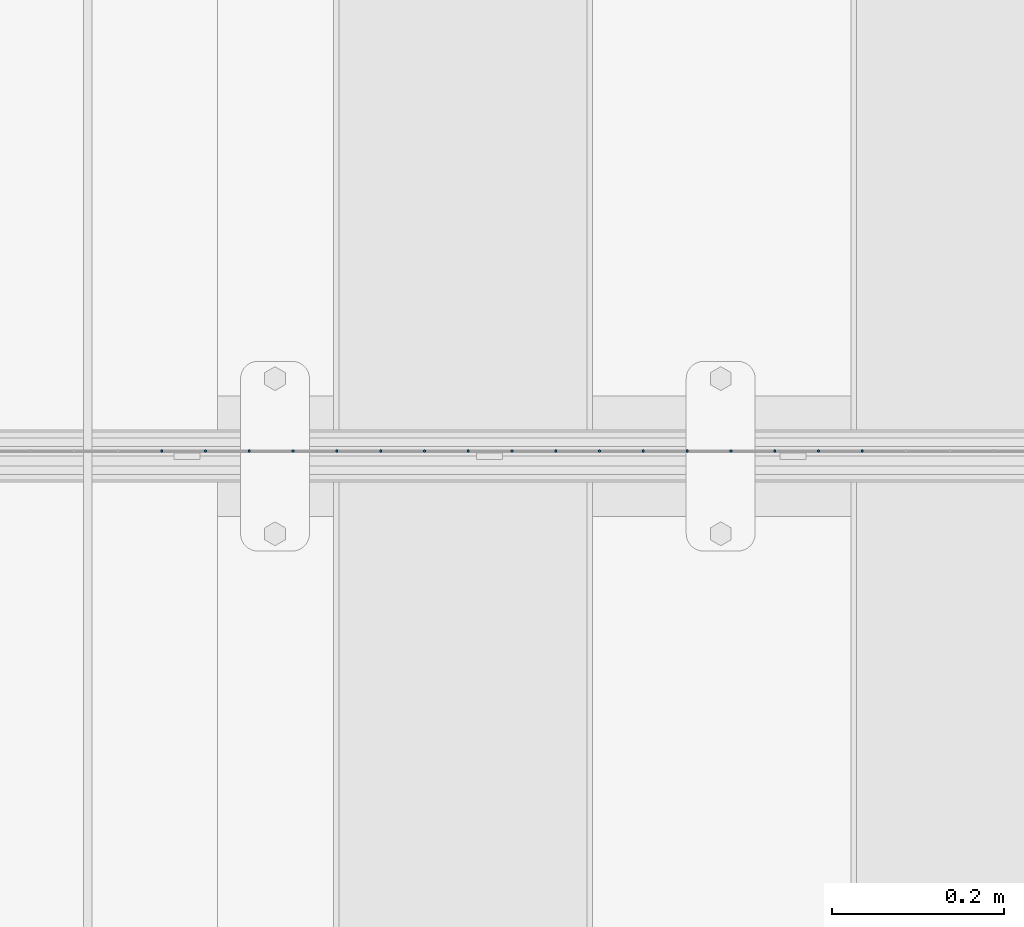
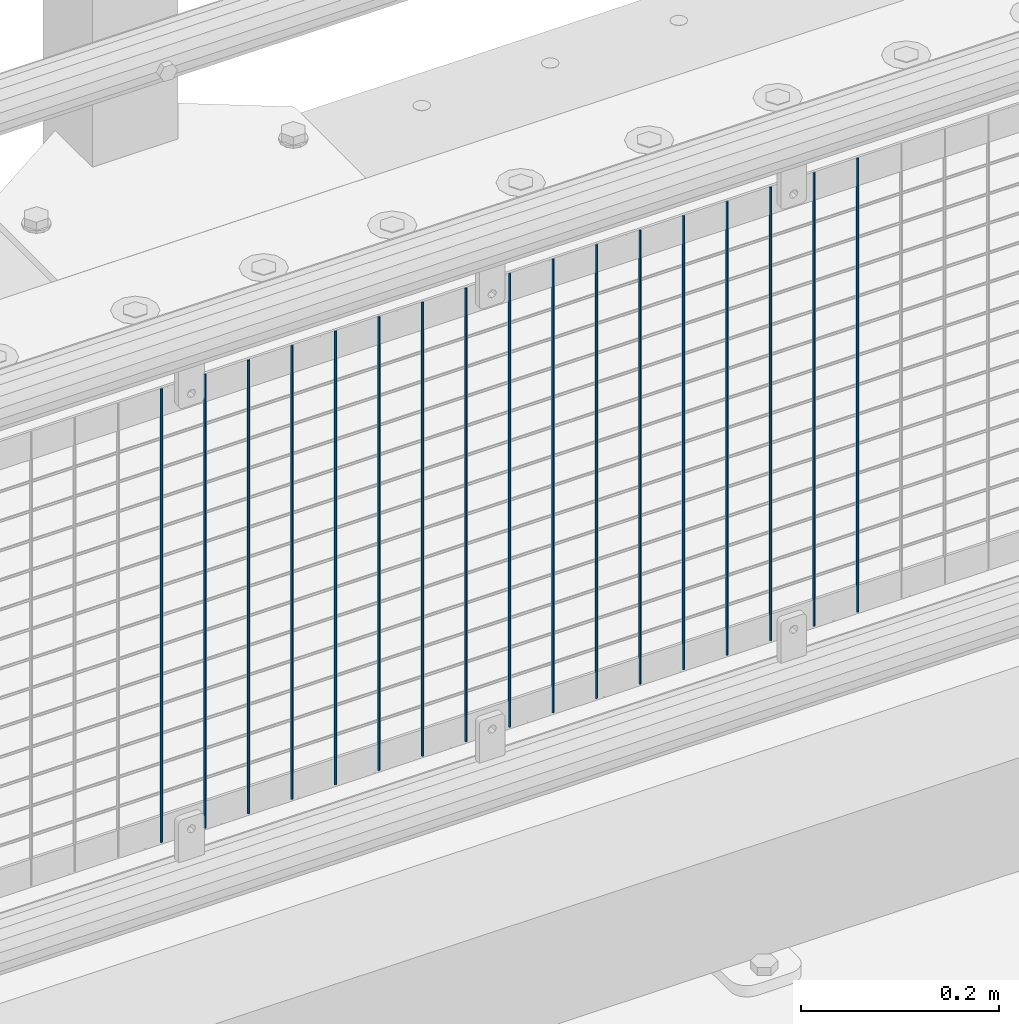
# One storey, part 94 of 242: 17 columns.
"""IFC2X3 building model written with IfcOpenShell, lengths in millimetres."""

from ifc_helpers import new_model, si_unit, frame, origin_with_axes, place, context, subcontext, project, spatial, faceted_brep, material, type_object, element, save


model = new_model("IFC2X3")

# Units and contexts
model_context = context("Model", 3, precision=1e-05, world=origin_with_axes())
body_context = subcontext(model_context, "Body", "Model", "MODEL_VIEW")
ifc_project = project(units=[si_unit("LENGTHUNIT", "METRE", prefix="MILLI"), si_unit("AREAUNIT", "SQUARE_METRE"), si_unit("VOLUMEUNIT", "CUBIC_METRE"), si_unit("MASSUNIT", "GRAM", prefix="KILO"), si_unit("TIMEUNIT", "SECOND"), si_unit("PLANEANGLEUNIT", "RADIAN"), si_unit("SOLIDANGLEUNIT", "STERADIAN"), si_unit("THERMODYNAMICTEMPERATUREUNIT", "DEGREE_CELSIUS"), si_unit("LUMINOUSINTENSITYUNIT", "LUMEN")], contexts=[model_context])

# Site, building, storey
site_placement = place(None, origin_with_axes())
site = spatial("IfcSite", under=ifc_project, at=site_placement, CompositionType="ELEMENT")
building_placement = place(site_placement, origin_with_axes())
building = spatial("IfcBuilding", under=site, at=building_placement, Name="Standard", CompositionType="ELEMENT")
storey_placement = place(building_placement, origin_with_axes())
storey = spatial("IfcBuildingStorey", under=building, at=storey_placement, Name="Undefined", CompositionType="ELEMENT", Elevation=0.0)

# Columns
ifc_material = material(Name="Misc_Undefined")
column_type = type_object("IfcColumnType", Name="D3", PredefinedType="NOTDEFINED")
for number, where, z_axis, x_axis in (
    (1, (-27516.761, -19329.5, 353.02), (-1.0, 0.0, 0.0), (0.0, 0.0, 1.0)),
    (2, (-27567.554, -19329.5, 353.02), (-1.0, 0.0, 0.0), (0.0, 0.0, 1.0)),
    (3, (-27618.347, -19329.5, 353.02), (-1.0, 0.0, 0.0), (0.0, 0.0, 1.0)),
    (4, (-27669.14, -19329.5, 353.02), (-1.0, 0.0, 0.0), (0.0, 0.0, 1.0)),
    (5, (-27719.933, -19329.5, 353.02), (-1.0, 0.0, 0.0), (0.0, 0.0, 1.0)),
    (6, (-27770.726, -19329.5, 353.02), (-1.0, 0.0, 0.0), (0.0, 0.0, 1.0)),
    (7, (-27821.519, -19329.5, 353.02), (-1.0, 0.0, 0.0), (0.0, 0.0, 1.0)),
    (8, (-27872.312, -19329.5, 353.02), (-1.0, 0.0, 0.0), (0.0, 0.0, 1.0)),
    (9, (-27923.105, -19329.5, 353.02), (-1.0, 0.0, 0.0), (0.0, 0.0, 1.0)),
    (10, (-27973.898, -19329.5, 353.02), (-1.0, 0.0, 0.0), (0.0, 0.0, 1.0)),
    (11, (-28024.691, -19329.5, 353.02), (-1.0, 0.0, 0.0), (0.0, 0.0, 1.0)),
    (12, (-28075.484, -19329.5, 353.02), (-1.0, 0.0, 0.0), (0.0, 0.0, 1.0)),
    (13, (-28126.277, -19329.5, 353.02), (-1.0, 0.0, 0.0), (0.0, 0.0, 1.0)),
    (14, (-28177.07, -19329.5, 353.02), (-1.0, 0.0, 0.0), (0.0, 0.0, 1.0)),
    (15, (-28227.863, -19329.5, 353.02), (-1.0, 0.0, 0.0), (0.0, 0.0, 1.0)),
    (16, (-28278.656, -19329.5, 353.02), (-1.0, 0.0, 0.0), (0.0, 0.0, 1.0)),
    (17, (-28329.449, -19329.5, 353.02), (-1.0, 0.0, 0.0), (0.0, 0.0, 1.0)),
):
    element("IfcColumn", number, at=place(storey_placement, frame(where, z_axis=z_axis, x_axis=x_axis)), inside=storey, type_object=column_type, material=ifc_material, ObjectType="D3", context=body_context, shape_type="Brep", body=[
        faceted_brep([(0.0, -1.50000000000364, 0.0), (-3.63797880709171e-12, -0.750000000003638, -1.29903810567669), (560.0, -0.75, -1.29903810567703), (560.0, -1.5, 0.0), (0.0, 0.749999999996362, -1.29903810567669), (560.0, 0.75, -1.29903810567703), (-3.63797880709171e-12, 1.49999999999636, 0.0), (560.0, 1.5, 0.0), (0.0, 0.749999999996362, 1.29903810567669), (560.0, 0.75, 1.29903810567703), (-3.63797880709171e-12, -0.750000000003638, 1.29903810567669), (560.0, -0.75, 1.29903810567703)], [[[0, 1, 2, 3]], [[1, 4, 5, 2]], [[4, 6, 7, 5]], [[6, 8, 9, 7]], [[8, 10, 11, 9]], [[10, 0, 3, 11]], [[5, 7, 9, 11, 3, 2]], [[10, 8, 6, 4, 1, 0]]]),
    ])

save(model, "model.ifc")
